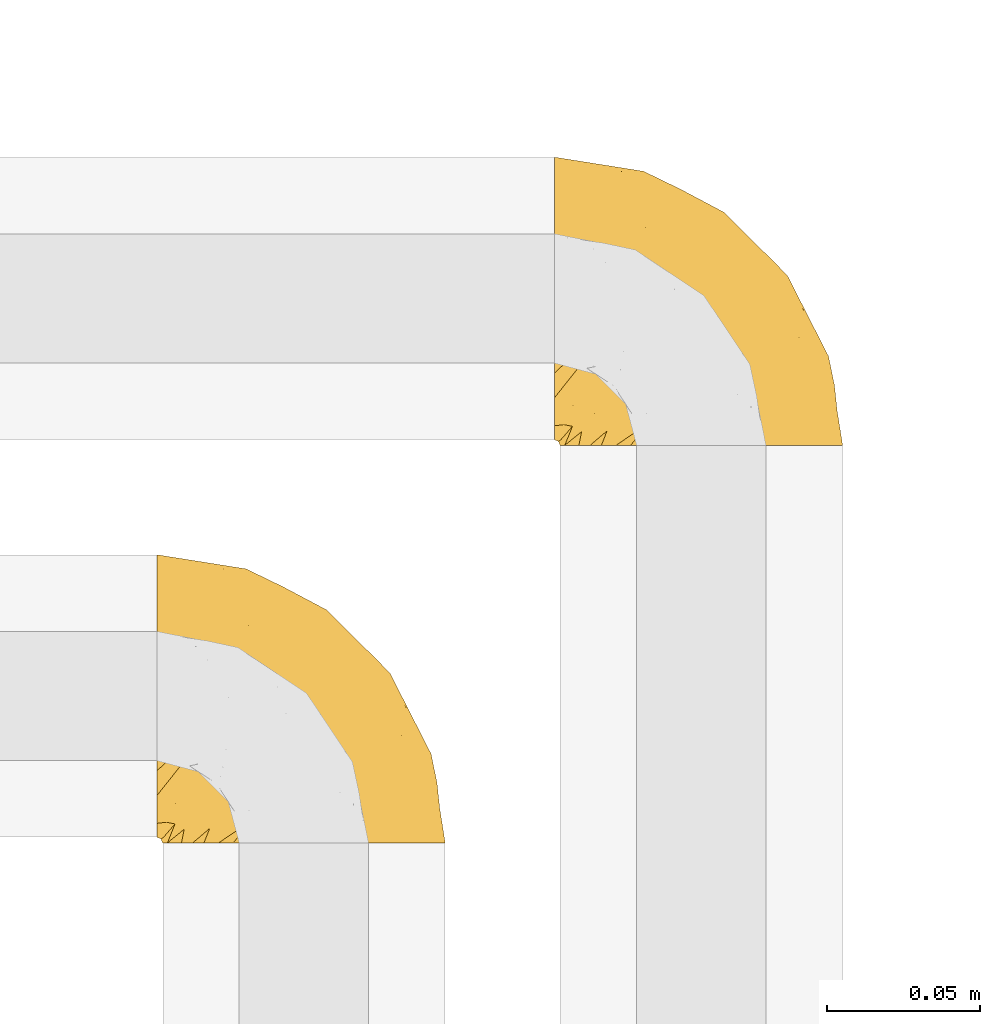
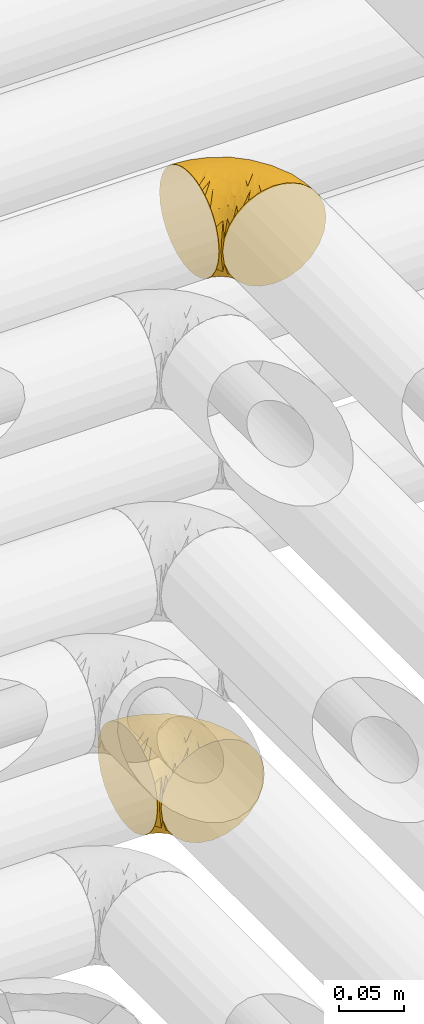
# One storey, part 277 of 827: 2 coverings.
"""IFC2X3 building model written with IfcOpenShell, lengths in millimetres."""

from ifc_helpers import new_model, entity, si_unit, converted_unit, derived_unit, direction, frame, origin, place, context, subcontext, project, spatial, faceted_brep, element, save


model = new_model("IFC2X3")

# Units and contexts
model_context = context("Model", 3, precision=0.01, world=origin(), true_north=direction((6.12303176911189e-17, 1.0)))
body_context = subcontext(model_context, "Body", "Model", "MODEL_VIEW")
ifc_project = project(units=[si_unit("LENGTHUNIT", "METRE", prefix="MILLI"), si_unit("AREAUNIT", "SQUARE_METRE"), si_unit("VOLUMEUNIT", "CUBIC_METRE"), converted_unit("PLANEANGLEUNIT", "DEGREE", entity("IfcRatioMeasure", 0.0174532925199433), si_unit("PLANEANGLEUNIT", "RADIAN"), dimensions=[0, 0, 0, 0, 0, 0, 0]), si_unit("MASSUNIT", "GRAM", prefix="KILO"), derived_unit("MASSDENSITYUNIT", [(si_unit("MASSUNIT", "GRAM", prefix="KILO"), 1), (si_unit("LENGTHUNIT", "METRE"), -3)]), derived_unit("MOMENTOFINERTIAUNIT", [(si_unit("LENGTHUNIT", "METRE"), 4)]), si_unit("TIMEUNIT", "SECOND"), si_unit("FREQUENCYUNIT", "HERTZ"), si_unit("THERMODYNAMICTEMPERATUREUNIT", "DEGREE_CELSIUS"), derived_unit("THERMALTRANSMITTANCEUNIT", [(si_unit("MASSUNIT", "GRAM", prefix="KILO"), 1), (si_unit("THERMODYNAMICTEMPERATUREUNIT", "KELVIN"), -1), (si_unit("TIMEUNIT", "SECOND"), -3)]), derived_unit("VOLUMETRICFLOWRATEUNIT", [(si_unit("LENGTHUNIT", "METRE"), 3), (si_unit("TIMEUNIT", "SECOND"), -1)]), derived_unit("MASSFLOWRATEUNIT", [(si_unit("MASSUNIT", "GRAM", prefix="KILO"), 1), (si_unit("TIMEUNIT", "SECOND"), -1)]), derived_unit("ROTATIONALFREQUENCYUNIT", [(si_unit("TIMEUNIT", "SECOND"), -1)]), si_unit("ELECTRICCURRENTUNIT", "AMPERE"), si_unit("ELECTRICVOLTAGEUNIT", "VOLT"), si_unit("POWERUNIT", "WATT"), si_unit("FORCEUNIT", "NEWTON", prefix="KILO"), si_unit("ILLUMINANCEUNIT", "LUX"), si_unit("LUMINOUSFLUXUNIT", "LUMEN"), si_unit("LUMINOUSINTENSITYUNIT", "CANDELA"), derived_unit("USERDEFINED", [(si_unit("MASSUNIT", "GRAM", prefix="KILO"), -1), (si_unit("LENGTHUNIT", "METRE"), -2), (si_unit("TIMEUNIT", "SECOND"), 3), (si_unit("LUMINOUSFLUXUNIT", "LUMEN"), 1)]), derived_unit("LINEARVELOCITYUNIT", [(si_unit("LENGTHUNIT", "METRE"), 1), (si_unit("TIMEUNIT", "SECOND"), -1)]), si_unit("PRESSUREUNIT", "PASCAL"), derived_unit("USERDEFINED", [(si_unit("LENGTHUNIT", "METRE"), -2), (si_unit("MASSUNIT", "GRAM", prefix="KILO"), 1), (si_unit("TIMEUNIT", "SECOND"), -2)]), derived_unit("LINEARFORCEUNIT", [(si_unit("MASSUNIT", "GRAM", prefix="KILO"), 1), (si_unit("LENGTHUNIT", "METRE"), 1), (si_unit("TIMEUNIT", "SECOND"), -2), (si_unit("LENGTHUNIT", "METRE"), -1)]), derived_unit("PLANARFORCEUNIT", [(si_unit("MASSUNIT", "GRAM", prefix="KILO"), 1), (si_unit("LENGTHUNIT", "METRE"), 1), (si_unit("TIMEUNIT", "SECOND"), -2), (si_unit("LENGTHUNIT", "METRE"), -2)])], contexts=[model_context])

# Site, building, storey
site_placement = place(None, origin())
site = spatial("IfcSite", under=ifc_project, at=site_placement, CompositionType="ELEMENT")
building_placement = place(site_placement, origin())
building = spatial("IfcBuilding", under=site, at=building_placement, CompositionType="ELEMENT")
storey_placement = place(building_placement, frame((0.0, 0.0, 28200.0)))
storey = spatial("IfcBuildingStorey", under=building, at=storey_placement, Name="08", CompositionType="ELEMENT", Elevation=28200.0)

# Coverings
covering_1_placement = place(storey_placement, frame((35680.44, 14440.41, 3352.2)))
element("IfcCovering", 1, at=covering_1_placement, inside=storey, Name=":ADSK_", ObjectType=":ADSK_", PredefinedType="INSULATION", context=body_context, shape_type="Brep", body=[
    faceted_brep([(1.6, 78.41, 83.91), (1.6, 85.72, 76.59), (1.6, 91.22, 67.83), (1.6, 94.64, 58.07), (1.6, 95.8, 47.8), (1.6, 94.64, 37.51), (1.6, 91.22, 27.74), (1.6, 85.71, 18.98), (1.6, 78.39, 11.67), (1.6, 69.63, 6.17), (1.6, 59.87, 2.75), (1.6, 49.6, 1.6), (1.6, 45.45, 2.06), (1.6, 42.38, 2.41), (1.6, 39.31, 2.75), (1.6, 34.43, 4.46), (1.6, 29.54, 6.17), (1.6, 25.16, 8.93), (1.6, 20.78, 11.68), (1.6, 17.13, 15.34), (1.6, 13.47, 19.0), (1.6, 7.97, 27.76), (1.6, 6.26, 32.64), (1.6, 4.55, 37.52), (1.6, 3.4, 47.8), (1.6, 4.55, 58.08), (1.6, 6.26, 62.96), (1.6, 7.97, 67.85), (1.6, 13.48, 76.61), (1.6, 17.14, 80.26), (1.6, 20.8, 83.92), (1.6, 25.18, 86.67), (1.6, 29.56, 89.42), (1.6, 34.44, 91.13), (1.6, 39.32, 92.84), (1.6, 42.39, 93.18), (1.6, 45.45, 93.53), (1.6, 49.6, 94.0), (1.6, 59.88, 92.84), (1.6, 69.65, 89.42), (3.4, 1.6, 47.8), (4.97, 1.6, 35.84), (9.58, 1.6, 24.7), (13.26, 1.6, 19.91), (16.93, 1.6, 15.13), (21.71, 1.6, 11.46), (26.5, 1.6, 7.78), (32.07, 1.6, 5.48), (37.64, 1.6, 3.17), (41.25, 1.6, 2.69), (43.34, 1.6, 2.42), (45.42, 1.6, 2.14), (49.6, 1.6, 1.6), (61.55, 1.6, 3.17), (72.7, 1.6, 7.78), (82.26, 1.6, 15.13), (89.61, 1.6, 24.7), (94.22, 1.6, 35.84), (95.8, 1.6, 47.8), (94.22, 1.6, 59.75), (89.61, 1.6, 70.9), (82.26, 1.6, 80.46), (72.7, 1.6, 87.81), (61.55, 1.6, 92.42), (49.6, 1.6, 94.0), (45.42, 1.6, 93.45), (41.25, 1.6, 92.9), (37.64, 1.6, 92.42), (32.07, 1.6, 90.11), (26.5, 1.6, 87.81), (21.71, 1.6, 84.13), (16.93, 1.6, 80.46), (13.26, 1.6, 75.68), (9.58, 1.6, 70.9), (4.97, 1.6, 59.75), (81.55, 36.81, 71.98), (90.4, 23.28, 63.6), (83.0, 45.8, 59.72), (91.18, 30.7, 47.8), (93.13, 21.2, 55.16), (94.0, 12.96, 47.8), (66.19, 66.19, 63.76), (70.92, 54.51, 72.22), (85.95, 17.98, 74.18), (49.74, 36.69, 92.52), (35.54, 35.54, 94.0), (38.14, 31.64, 94.0), (40.74, 27.75, 94.0), (43.34, 23.86, 94.0), (45.94, 19.96, 94.0), (77.59, 22.8, 82.14), (71.17, 42.67, 80.34), (65.81, 33.21, 87.52), (59.03, 59.45, 79.59), (45.85, 71.5, 78.25), (45.79, 62.66, 85.01), (41.42, 54.5, 90.25), (34.51, 47.57, 93.2), (56.04, 48.81, 87.23), (15.15, 74.98, 85.55), (56.51, 18.7, 93.0), (68.39, 15.75, 89.31), (23.33, 91.17, 61.31), (42.86, 85.28, 56.86), (39.42, 82.58, 68.34), (53.58, 75.78, 65.71), (59.17, 74.98, 56.99), (59.06, 67.27, 72.15), (22.63, 87.38, 70.34), (20.55, 82.04, 78.36), (12.96, 94.0, 47.8), (56.96, 77.8, 47.8), (67.38, 67.38, 47.8), (18.72, 56.2, 93.06), (5.33, 48.85, 94.0), (9.07, 48.11, 94.0), (11.79, 47.57, 94.0), (14.51, 47.03, 94.0), (17.24, 46.48, 94.0), (19.96, 45.94, 94.0), (21.03, 65.78, 89.88), (46.48, 17.24, 94.0), (47.03, 14.51, 94.0), (47.57, 11.79, 94.0), (48.11, 9.07, 94.0), (48.48, 7.2, 94.0), (48.85, 5.33, 94.0), (30.7, 91.18, 47.8), (23.86, 43.34, 94.0), (27.75, 40.74, 94.0), (31.64, 38.14, 94.0), (31.26, 72.73, 83.7), (77.8, 56.96, 47.8), (72.75, 62.23, 55.9), (43.83, 84.49, 47.8), (84.49, 43.83, 47.8), (14.58, 12.05, 81.75), (16.17, 18.95, 86.43), (10.82, 13.02, 79.8), (4.64, 8.34, 69.84), (7.71, 14.63, 79.5), (25.13, 11.09, 88.08), (32.66, 13.66, 91.6), (34.94, 20.08, 92.93), (36.76, 9.61, 92.43), (40.48, 9.48, 93.24), (39.25, 16.1, 93.36), (3.69, 3.42, 57.25), (13.99, 26.63, 89.41), (21.85, 33.72, 92.89), (17.93, 34.77, 92.66), (15.11, 6.75, 79.58), (21.14, 13.31, 86.51), (7.21, 19.94, 83.91), (9.47, 27.05, 88.76), (32.27, 8.67, 90.94), (25.68, 26.11, 91.94), (22.18, 29.3, 91.98), (18.79, 6.32, 82.79), (10.12, 39.92, 93.16), (10.45, 6.04, 73.94), (11.29, 34.4, 91.89), (2.87, 2.87, 47.8), (31.16, 20.92, 92.22), (12.7, 21.11, 86.29), (6.31, 27.43, 88.56), (25.62, 7.54, 87.72), (21.18, 18.45, 88.33), (28.81, 23.88, 92.18), (7.45, 7.77, 71.78), (21.17, 18.43, 7.27), (16.17, 18.93, 9.17), (25.69, 26.08, 3.66), (48.85, 5.33, 1.6), (47.03, 14.51, 1.6), (47.57, 11.79, 1.6), (48.11, 9.07, 1.6), (3.69, 3.42, 38.35), (7.44, 7.76, 23.84), (14.51, 47.03, 1.6), (11.79, 47.57, 1.6), (5.33, 48.85, 1.6), (9.07, 48.11, 1.6), (7.71, 14.62, 16.1), (9.47, 27.03, 6.84), (34.94, 20.08, 2.66), (31.16, 20.92, 3.37), (40.74, 27.75, 1.6), (38.14, 31.64, 1.6), (18.79, 6.33, 12.8), (36.76, 9.61, 3.16), (40.48, 9.48, 2.35), (4.63, 8.33, 25.77), (21.14, 13.3, 9.09), (15.11, 6.74, 16.02), (14.58, 12.04, 13.85), (43.34, 23.86, 1.6), (45.94, 19.96, 1.6), (39.25, 16.1, 2.23), (7.21, 19.93, 11.69), (12.69, 21.1, 9.31), (10.14, 39.92, 2.43), (21.81, 33.68, 2.71), (22.19, 29.28, 3.61), (14.0, 26.62, 6.18), (6.66, 27.87, 6.77), (17.92, 34.75, 2.93), (10.45, 6.04, 21.66), (31.64, 38.14, 1.6), (10.64, 12.79, 16.09), (11.31, 34.41, 3.7), (19.96, 45.94, 1.6), (23.86, 43.34, 1.6), (27.75, 40.74, 1.6), (32.66, 13.66, 3.99), (46.48, 17.24, 1.6), (32.27, 8.67, 4.65), (25.13, 11.09, 7.51), (35.54, 35.54, 1.6), (28.77, 23.83, 3.43), (23.36, 6.03, 9.46), (17.24, 46.48, 1.6), (47.58, 34.52, 2.4), (93.13, 21.2, 40.43), (77.44, 23.82, 13.57), (66.78, 41.32, 11.3), (71.68, 47.62, 18.65), (74.96, 52.66, 27.26), (81.55, 36.81, 23.61), (36.7, 49.75, 3.07), (56.9, 19.07, 2.69), (83.0, 45.8, 35.87), (90.4, 23.28, 31.99), (67.83, 21.35, 6.71), (85.95, 17.98, 21.41), (39.41, 82.57, 27.24), (23.33, 91.17, 34.26), (42.87, 85.27, 38.73), (53.92, 73.89, 26.97), (66.19, 66.19, 31.83), (64.12, 62.43, 23.4), (33.13, 63.53, 6.91), (23.1, 58.45, 3.4), (16.98, 67.16, 5.84), (55.72, 76.72, 35.73), (72.75, 62.22, 39.69), (23.77, 81.54, 17.6), (18.41, 74.8, 10.38), (43.7, 75.83, 20.6), (54.53, 41.45, 5.36), (17.73, 88.2, 24.84), (38.98, 71.6, 13.87), (50.28, 56.23, 9.06), (59.02, 59.44, 15.99)], [[[0, 1, 2, 3, 4, 5, 6, 7, 8, 9, 10, 11, 12, 13, 14, 15, 16, 17, 18, 19, 20, 21, 22, 23, 24, 25, 26, 27, 28, 29, 30, 31, 32, 33, 34, 35, 36, 37, 38, 39]], [[40, 41, 42, 43, 44, 45, 46, 47, 48, 49, 50, 51, 52, 53, 54, 55, 56, 57, 58, 59, 60, 61, 62, 63, 64, 65, 66, 67, 68, 69, 70, 71, 72, 73, 74]], [[75, 76, 77]], [[78, 79, 80]], [[77, 81, 82]], [[76, 75, 83]], [[84, 85, 86, 87, 88, 89]], [[90, 91, 92]], [[76, 60, 59]], [[93, 94, 95]], [[90, 62, 61]], [[83, 61, 60]], [[96, 97, 84]], [[98, 93, 95]], [[0, 39, 99]], [[100, 84, 89]], [[62, 101, 63]], [[2, 102, 3]], [[92, 84, 100]], [[103, 102, 104]], [[103, 105, 106]], [[93, 107, 94]], [[1, 108, 2]], [[92, 101, 90]], [[108, 1, 109]], [[102, 110, 3]], [[93, 82, 107]], [[102, 108, 104]], [[111, 106, 112]], [[109, 0, 99]], [[113, 37, 114, 115, 116, 117, 118, 119]], [[120, 38, 113]], [[100, 89, 121, 122, 123, 124, 125, 126, 64]], [[127, 102, 103]], [[97, 119, 128, 129, 130, 85]], [[99, 120, 131]], [[132, 133, 77]], [[59, 80, 79]], [[1, 0, 109]], [[98, 84, 92]], [[94, 109, 131]], [[120, 39, 38]], [[93, 91, 82]], [[104, 94, 105]], [[97, 113, 119]], [[95, 120, 96]], [[83, 90, 61]], [[91, 93, 98]], [[64, 63, 100]], [[100, 63, 101]], [[77, 76, 79]], [[133, 106, 81]], [[84, 97, 85]], [[113, 96, 120]], [[113, 97, 96]], [[37, 113, 38]], [[110, 102, 127]], [[110, 4, 3]], [[103, 111, 134, 127]], [[90, 75, 91]], [[82, 81, 107]], [[91, 75, 82]], [[77, 82, 75]], [[76, 83, 60]], [[90, 83, 75]], [[105, 107, 81]], [[94, 131, 95]], [[105, 94, 107]], [[109, 94, 104]], [[120, 95, 131]], [[98, 95, 96]], [[84, 98, 96]], [[98, 92, 91]], [[106, 105, 81]], [[103, 104, 105]], [[133, 132, 112]], [[103, 106, 111]], [[77, 78, 135, 132]], [[106, 133, 112]], [[77, 133, 81]], [[120, 99, 39]], [[109, 99, 131]], [[59, 58, 80]], [[59, 79, 76]], [[90, 101, 62]], [[100, 101, 92]], [[2, 108, 102]], [[109, 104, 108]], [[78, 77, 79]], [[136, 137, 138]], [[27, 139, 140]], [[141, 142, 143]], [[144, 145, 121]], [[146, 89, 88]], [[147, 139, 25]], [[148, 149, 150]], [[136, 151, 152]], [[147, 40, 74]], [[24, 147, 25]], [[153, 148, 154]], [[33, 116, 34]], [[73, 72, 151]], [[114, 37, 36, 35, 34, 116, 115]], [[146, 155, 144]], [[156, 85, 130]], [[157, 149, 148]], [[151, 158, 152]], [[117, 33, 159]], [[29, 153, 154]], [[160, 74, 73]], [[161, 128, 119]], [[66, 65, 64, 126, 125, 124, 123, 122, 67]], [[162, 147, 24]], [[27, 140, 28]], [[149, 129, 150]], [[139, 27, 26, 25]], [[68, 144, 69]], [[129, 128, 150]], [[163, 87, 86]], [[130, 129, 149]], [[122, 145, 67]], [[153, 164, 148]], [[161, 119, 159]], [[165, 30, 154]], [[150, 154, 148]], [[128, 161, 150]], [[30, 165, 31]], [[145, 144, 68]], [[89, 146, 144]], [[87, 163, 143]], [[166, 155, 142]], [[88, 87, 143]], [[161, 154, 150]], [[154, 30, 29]], [[29, 28, 153]], [[28, 140, 153]], [[164, 153, 140]], [[140, 137, 164]], [[157, 148, 164]], [[156, 130, 157]], [[164, 137, 157]], [[157, 137, 156]], [[167, 137, 136]], [[168, 85, 156]], [[152, 168, 167]], [[167, 168, 156]], [[163, 152, 141]], [[71, 158, 72]], [[152, 167, 136]], [[88, 142, 146]], [[144, 155, 69]], [[146, 142, 155]], [[70, 166, 71]], [[142, 141, 166]], [[70, 69, 155]], [[141, 158, 71]], [[160, 73, 151]], [[138, 137, 140]], [[160, 136, 169]], [[136, 160, 151]], [[74, 160, 169]], [[152, 158, 141]], [[151, 72, 158]], [[168, 152, 163]], [[137, 167, 156]], [[163, 86, 168]], [[85, 168, 86]], [[116, 33, 117]], [[130, 149, 157]], [[67, 145, 68]], [[121, 89, 144]], [[145, 122, 121]], [[40, 147, 162]], [[169, 147, 74]], [[159, 33, 32]], [[161, 159, 32]], [[159, 119, 118, 117]], [[139, 147, 169]], [[139, 169, 138]], [[161, 32, 31]], [[141, 143, 163]], [[88, 143, 142]], [[71, 166, 141]], [[155, 166, 70]], [[139, 138, 140]], [[169, 136, 138]], [[154, 161, 165]], [[161, 31, 165]], [[170, 171, 172]], [[173, 52, 51, 50, 49, 48, 174, 175, 176]], [[177, 178, 41]], [[179, 15, 180]], [[12, 11, 181, 182, 180, 14, 13]], [[183, 21, 20]], [[19, 18, 184]], [[185, 186, 187]], [[186, 188, 187]], [[43, 189, 44]], [[190, 191, 47]], [[23, 22, 21, 192]], [[193, 194, 195]], [[40, 162, 177]], [[196, 197, 198]], [[24, 23, 177]], [[199, 200, 183]], [[201, 15, 179]], [[47, 46, 190]], [[202, 203, 204]], [[203, 172, 171]], [[205, 206, 184]], [[207, 41, 178]], [[16, 15, 201]], [[14, 180, 15]], [[204, 203, 200]], [[208, 203, 202]], [[162, 24, 177]], [[48, 47, 191]], [[198, 197, 190]], [[199, 184, 204]], [[171, 195, 209]], [[210, 211, 212]], [[206, 212, 213]], [[205, 17, 210]], [[184, 206, 204]], [[210, 212, 206]], [[185, 196, 214]], [[190, 215, 191]], [[216, 45, 214]], [[186, 217, 193]], [[190, 216, 198]], [[199, 20, 19]], [[196, 185, 187]], [[199, 183, 20]], [[184, 199, 19]], [[199, 204, 200]], [[206, 202, 204]], [[171, 183, 200]], [[203, 208, 172]], [[172, 208, 218]], [[171, 200, 203]], [[218, 188, 219]], [[195, 170, 193]], [[217, 186, 185]], [[193, 219, 186]], [[193, 170, 219]], [[207, 194, 42]], [[217, 220, 189]], [[216, 190, 46]], [[214, 196, 198]], [[44, 220, 45]], [[214, 198, 216]], [[216, 46, 45]], [[214, 45, 220]], [[42, 194, 43]], [[189, 193, 217]], [[207, 195, 194]], [[209, 195, 178]], [[41, 207, 42]], [[195, 207, 178]], [[43, 194, 189]], [[193, 189, 194]], [[171, 170, 195]], [[170, 172, 219]], [[218, 219, 172]], [[188, 186, 219]], [[206, 213, 202]], [[208, 202, 213]], [[201, 210, 16]], [[215, 190, 197]], [[215, 174, 191]], [[174, 48, 191]], [[201, 179, 221, 211]], [[210, 201, 211]], [[23, 192, 177]], [[40, 177, 41]], [[178, 177, 192]], [[21, 183, 192]], [[209, 192, 183]], [[205, 18, 17]], [[17, 16, 210]], [[217, 185, 214]], [[189, 220, 44]], [[214, 220, 217]], [[192, 209, 178]], [[171, 209, 183]], [[206, 205, 210]], [[18, 205, 184]], [[222, 197, 196, 187, 188, 218]], [[57, 223, 80]], [[224, 225, 226]], [[226, 227, 228]], [[229, 218, 208, 213, 212, 211]], [[230, 52, 173, 176, 175, 174, 215, 197]], [[231, 232, 228]], [[231, 78, 223]], [[223, 57, 232]], [[224, 233, 225]], [[233, 54, 53]], [[234, 232, 56]], [[56, 55, 234]], [[234, 224, 228]], [[235, 236, 237]], [[224, 55, 54]], [[238, 239, 240]], [[52, 230, 53]], [[241, 242, 243]], [[239, 244, 245]], [[11, 10, 242]], [[236, 6, 5]], [[7, 246, 8]], [[8, 247, 9]], [[238, 248, 235]], [[222, 229, 249]], [[242, 211, 221, 179, 180, 182, 181, 11]], [[233, 53, 230]], [[111, 112, 244]], [[250, 6, 236]], [[247, 251, 241]], [[6, 250, 7]], [[127, 236, 110]], [[249, 229, 252]], [[247, 8, 246]], [[235, 246, 250]], [[236, 5, 110]], [[235, 244, 238]], [[237, 236, 127]], [[243, 9, 247]], [[252, 229, 241]], [[56, 232, 57]], [[222, 230, 197]], [[225, 249, 252]], [[249, 233, 230]], [[54, 233, 224]], [[231, 228, 227]], [[245, 132, 231]], [[249, 225, 233]], [[226, 225, 253]], [[235, 250, 236]], [[246, 7, 250]], [[251, 247, 246]], [[243, 247, 241]], [[248, 246, 235]], [[252, 251, 253]], [[229, 222, 218]], [[230, 222, 249]], [[5, 4, 110]], [[237, 127, 134, 111]], [[238, 244, 239]], [[224, 234, 55]], [[232, 234, 228]], [[242, 241, 229]], [[10, 9, 243]], [[211, 242, 229]], [[10, 243, 242]], [[80, 223, 78]], [[80, 58, 57]], [[231, 223, 232]], [[227, 240, 239]], [[224, 226, 228]], [[240, 226, 253]], [[227, 239, 245]], [[226, 240, 227]], [[251, 248, 253]], [[240, 253, 248]], [[244, 235, 237]], [[237, 111, 244]], [[132, 245, 112]], [[112, 245, 244]], [[135, 78, 231, 132]], [[227, 245, 231]], [[248, 238, 240]], [[246, 248, 251]], [[251, 252, 241]], [[225, 252, 253]]]),
])
covering_2_placement = place(storey_placement, frame((35550.5, 14310.41, 2952.2)))
element("IfcCovering", 2, at=covering_2_placement, inside=storey, Name=":ADSK_", ObjectType=":ADSK_", PredefinedType="INSULATION", context=body_context, shape_type="Brep", body=[
    faceted_brep([(1.6, 59.88, 92.84), (1.6, 69.65, 89.42), (1.6, 78.41, 83.91), (1.6, 85.72, 76.59), (1.6, 91.22, 67.83), (1.6, 94.64, 58.07), (1.6, 95.8, 47.8), (1.6, 94.64, 37.51), (1.6, 91.22, 27.74), (1.6, 85.71, 18.98), (1.6, 78.39, 11.67), (1.6, 69.63, 6.17), (1.6, 59.87, 2.75), (1.6, 49.6, 1.6), (1.6, 45.45, 2.06), (1.6, 42.38, 2.41), (1.6, 39.31, 2.75), (1.6, 34.43, 4.46), (1.6, 29.54, 6.17), (1.6, 25.16, 8.93), (1.6, 20.78, 11.68), (1.6, 17.13, 15.34), (1.6, 13.47, 19.0), (1.6, 7.97, 27.76), (1.6, 6.26, 32.64), (1.6, 4.55, 37.52), (1.6, 3.4, 47.8), (1.6, 4.55, 58.08), (1.6, 6.26, 62.96), (1.6, 7.97, 67.85), (1.6, 13.48, 76.61), (1.6, 17.14, 80.26), (1.6, 20.8, 83.92), (1.6, 25.18, 86.67), (1.6, 29.56, 89.42), (1.6, 34.44, 91.13), (1.6, 39.32, 92.84), (1.6, 42.39, 93.18), (1.6, 45.45, 93.53), (1.6, 49.6, 94.0), (3.4, 1.6, 47.8), (4.97, 1.6, 35.84), (9.58, 1.6, 24.7), (13.26, 1.6, 19.91), (16.93, 1.6, 15.13), (21.71, 1.6, 11.46), (26.5, 1.6, 7.78), (32.07, 1.6, 5.48), (37.64, 1.6, 3.17), (41.25, 1.6, 2.69), (43.34, 1.6, 2.42), (45.42, 1.6, 2.14), (49.6, 1.6, 1.6), (61.55, 1.6, 3.17), (72.7, 1.6, 7.78), (82.26, 1.6, 15.13), (89.61, 1.6, 24.7), (94.22, 1.6, 35.84), (95.8, 1.6, 47.8), (94.22, 1.6, 59.75), (89.61, 1.6, 70.9), (82.26, 1.6, 80.46), (72.7, 1.6, 87.81), (61.55, 1.6, 92.42), (49.6, 1.6, 94.0), (45.42, 1.6, 93.45), (41.25, 1.6, 92.9), (37.64, 1.6, 92.42), (32.07, 1.6, 90.11), (26.5, 1.6, 87.81), (21.71, 1.6, 84.13), (16.93, 1.6, 80.46), (13.26, 1.6, 75.68), (9.58, 1.6, 70.9), (4.97, 1.6, 59.75), (81.55, 36.81, 71.98), (90.4, 23.28, 63.6), (83.0, 45.8, 59.72), (91.18, 30.7, 47.8), (93.13, 21.2, 55.16), (94.0, 12.96, 47.8), (66.19, 66.19, 63.76), (70.92, 54.51, 72.22), (85.95, 17.98, 74.18), (49.74, 36.69, 92.52), (35.54, 35.54, 94.0), (38.14, 31.64, 94.0), (40.74, 27.75, 94.0), (43.34, 23.86, 94.0), (45.94, 19.96, 94.0), (77.59, 22.8, 82.14), (71.17, 42.67, 80.34), (65.81, 33.21, 87.52), (59.03, 59.45, 79.59), (45.85, 71.5, 78.25), (45.79, 62.66, 85.01), (41.42, 54.5, 90.25), (34.51, 47.57, 93.2), (56.04, 48.81, 87.23), (15.15, 74.98, 85.55), (56.51, 18.7, 93.0), (68.39, 15.75, 89.31), (23.33, 91.17, 61.31), (42.86, 85.28, 56.86), (39.42, 82.58, 68.34), (53.58, 75.78, 65.71), (59.17, 74.98, 56.99), (59.06, 67.27, 72.15), (22.63, 87.38, 70.34), (20.55, 82.04, 78.36), (12.96, 94.0, 47.8), (56.96, 77.8, 47.8), (67.38, 67.38, 47.8), (18.72, 56.2, 93.06), (5.33, 48.85, 94.0), (9.07, 48.11, 94.0), (11.79, 47.57, 94.0), (14.51, 47.03, 94.0), (17.24, 46.48, 94.0), (19.96, 45.94, 94.0), (21.03, 65.78, 89.88), (46.48, 17.24, 94.0), (47.03, 14.51, 94.0), (47.57, 11.79, 94.0), (48.11, 9.07, 94.0), (48.48, 7.2, 94.0), (48.85, 5.33, 94.0), (30.7, 91.18, 47.8), (23.86, 43.34, 94.0), (27.75, 40.74, 94.0), (31.64, 38.14, 94.0), (31.26, 72.73, 83.7), (77.8, 56.96, 47.8), (72.75, 62.23, 55.9), (43.83, 84.49, 47.8), (84.49, 43.83, 47.8), (14.58, 12.05, 81.75), (16.17, 18.95, 86.43), (10.82, 13.02, 79.8), (4.64, 8.34, 69.84), (7.71, 14.63, 79.5), (25.13, 11.09, 88.08), (32.66, 13.66, 91.6), (34.94, 20.08, 92.93), (36.76, 9.61, 92.43), (40.48, 9.48, 93.24), (39.25, 16.1, 93.36), (3.69, 3.42, 57.25), (13.99, 26.63, 89.41), (21.85, 33.72, 92.89), (17.93, 34.77, 92.66), (15.11, 6.75, 79.58), (21.14, 13.31, 86.51), (7.21, 19.94, 83.91), (9.47, 27.05, 88.76), (32.27, 8.67, 90.94), (25.68, 26.11, 91.94), (22.18, 29.3, 91.98), (18.79, 6.32, 82.79), (10.12, 39.92, 93.16), (10.45, 6.04, 73.94), (11.29, 34.4, 91.89), (2.87, 2.87, 47.8), (31.16, 20.92, 92.22), (12.7, 21.11, 86.29), (6.31, 27.43, 88.56), (25.62, 7.54, 87.72), (21.18, 18.45, 88.33), (28.81, 23.88, 92.18), (7.45, 7.77, 71.78), (21.14, 13.3, 9.09), (25.13, 11.09, 7.51), (18.79, 6.33, 12.8), (48.85, 5.33, 1.6), (47.03, 14.51, 1.6), (47.57, 11.79, 1.6), (48.11, 9.07, 1.6), (3.69, 3.42, 38.35), (7.44, 7.76, 23.84), (14.51, 47.03, 1.6), (11.79, 47.57, 1.6), (5.33, 48.85, 1.6), (9.07, 48.11, 1.6), (7.71, 14.62, 16.1), (9.47, 27.03, 6.84), (34.94, 20.08, 2.66), (31.16, 20.92, 3.37), (40.74, 27.75, 1.6), (38.14, 31.64, 1.6), (36.76, 9.61, 3.16), (40.48, 9.48, 2.35), (4.63, 8.33, 25.77), (15.11, 6.74, 16.02), (14.58, 12.04, 13.85), (43.34, 23.86, 1.6), (45.94, 19.96, 1.6), (39.25, 16.1, 2.23), (7.21, 19.93, 11.69), (12.69, 21.1, 9.31), (10.14, 39.92, 2.43), (21.81, 33.68, 2.71), (22.19, 29.28, 3.61), (14.0, 26.62, 6.18), (25.69, 26.08, 3.66), (16.17, 18.93, 9.17), (6.66, 27.87, 6.77), (17.92, 34.75, 2.93), (10.45, 6.04, 21.66), (31.64, 38.14, 1.6), (10.64, 12.79, 16.09), (11.31, 34.41, 3.7), (19.96, 45.94, 1.6), (23.86, 43.34, 1.6), (27.75, 40.74, 1.6), (32.66, 13.66, 3.99), (46.48, 17.24, 1.6), (32.27, 8.67, 4.65), (35.54, 35.54, 1.6), (28.77, 23.83, 3.43), (21.17, 18.43, 7.27), (23.36, 6.03, 9.46), (17.24, 46.48, 1.6), (47.58, 34.52, 2.4), (93.13, 21.2, 40.43), (77.44, 23.82, 13.57), (66.78, 41.32, 11.3), (71.68, 47.62, 18.65), (74.96, 52.66, 27.26), (81.55, 36.81, 23.61), (36.7, 49.75, 3.07), (56.9, 19.07, 2.69), (83.0, 45.8, 35.87), (90.4, 23.28, 31.99), (67.83, 21.35, 6.71), (85.95, 17.98, 21.41), (39.41, 82.57, 27.24), (23.33, 91.17, 34.26), (42.87, 85.27, 38.73), (53.92, 73.89, 26.97), (66.19, 66.19, 31.83), (64.12, 62.43, 23.4), (33.13, 63.53, 6.91), (23.1, 58.45, 3.4), (16.98, 67.16, 5.84), (55.72, 76.72, 35.73), (72.75, 62.22, 39.69), (23.77, 81.54, 17.6), (18.41, 74.8, 10.38), (43.7, 75.83, 20.6), (54.53, 41.45, 5.36), (17.73, 88.2, 24.84), (38.98, 71.6, 13.87), (50.28, 56.23, 9.06), (59.02, 59.44, 15.99)], [[[0, 1, 2, 3, 4, 5, 6, 7, 8, 9, 10, 11, 12, 13, 14, 15, 16, 17, 18, 19, 20, 21, 22, 23, 24, 25, 26, 27, 28, 29, 30, 31, 32, 33, 34, 35, 36, 37, 38, 39]], [[40, 41, 42, 43, 44, 45, 46, 47, 48, 49, 50, 51, 52, 53, 54, 55, 56, 57, 58, 59, 60, 61, 62, 63, 64, 65, 66, 67, 68, 69, 70, 71, 72, 73, 74]], [[75, 76, 77]], [[78, 79, 80]], [[77, 81, 82]], [[76, 75, 83]], [[84, 85, 86, 87, 88, 89]], [[90, 91, 92]], [[76, 60, 59]], [[93, 94, 95]], [[90, 62, 61]], [[83, 61, 60]], [[96, 97, 84]], [[98, 93, 95]], [[2, 1, 99]], [[100, 84, 89]], [[62, 101, 63]], [[4, 102, 5]], [[92, 84, 100]], [[103, 102, 104]], [[103, 105, 106]], [[93, 107, 94]], [[3, 108, 4]], [[92, 101, 90]], [[108, 3, 109]], [[102, 110, 5]], [[93, 82, 107]], [[102, 108, 104]], [[111, 106, 112]], [[109, 2, 99]], [[113, 39, 114, 115, 116, 117, 118, 119]], [[120, 0, 113]], [[100, 89, 121, 122, 123, 124, 125, 126, 64]], [[127, 102, 103]], [[97, 119, 128, 129, 130, 85]], [[99, 120, 131]], [[132, 133, 77]], [[59, 80, 79]], [[3, 2, 109]], [[98, 84, 92]], [[94, 109, 131]], [[120, 1, 0]], [[93, 91, 82]], [[104, 94, 105]], [[97, 113, 119]], [[95, 120, 96]], [[83, 90, 61]], [[91, 93, 98]], [[64, 63, 100]], [[100, 63, 101]], [[77, 76, 79]], [[133, 106, 81]], [[84, 97, 85]], [[113, 96, 120]], [[113, 97, 96]], [[39, 113, 0]], [[110, 102, 127]], [[110, 6, 5]], [[103, 111, 134, 127]], [[90, 75, 91]], [[82, 81, 107]], [[91, 75, 82]], [[77, 82, 75]], [[76, 83, 60]], [[90, 83, 75]], [[105, 107, 81]], [[94, 131, 95]], [[105, 94, 107]], [[109, 94, 104]], [[120, 95, 131]], [[98, 95, 96]], [[84, 98, 96]], [[98, 92, 91]], [[106, 105, 81]], [[103, 104, 105]], [[112, 106, 133]], [[103, 106, 111]], [[112, 133, 132]], [[81, 77, 133]], [[77, 78, 135, 132]], [[120, 99, 1]], [[109, 99, 131]], [[59, 58, 80]], [[59, 79, 76]], [[90, 101, 62]], [[100, 101, 92]], [[4, 108, 102]], [[109, 104, 108]], [[78, 77, 79]], [[136, 137, 138]], [[29, 139, 140]], [[141, 142, 143]], [[144, 145, 121]], [[146, 89, 88]], [[147, 139, 27]], [[148, 149, 150]], [[136, 151, 152]], [[147, 40, 74]], [[26, 147, 27]], [[153, 148, 154]], [[35, 116, 36]], [[73, 72, 151]], [[114, 39, 38, 37, 36, 116, 115]], [[146, 155, 144]], [[156, 85, 130]], [[157, 149, 148]], [[151, 158, 152]], [[117, 35, 159]], [[31, 153, 154]], [[160, 74, 73]], [[161, 128, 119]], [[66, 65, 64, 126, 125, 124, 123, 122, 67]], [[162, 147, 26]], [[29, 140, 30]], [[149, 129, 150]], [[139, 29, 28, 27]], [[68, 144, 69]], [[129, 128, 150]], [[163, 87, 86]], [[130, 129, 149]], [[122, 145, 67]], [[153, 164, 148]], [[161, 119, 159]], [[165, 32, 154]], [[150, 154, 148]], [[128, 161, 150]], [[32, 165, 33]], [[145, 144, 68]], [[89, 146, 144]], [[87, 163, 143]], [[166, 155, 142]], [[88, 87, 143]], [[161, 154, 150]], [[154, 32, 31]], [[31, 30, 153]], [[30, 140, 153]], [[164, 153, 140]], [[140, 137, 164]], [[157, 148, 164]], [[156, 130, 157]], [[164, 137, 157]], [[157, 137, 156]], [[167, 137, 136]], [[168, 85, 156]], [[152, 168, 167]], [[167, 168, 156]], [[163, 152, 141]], [[71, 158, 72]], [[152, 167, 136]], [[88, 142, 146]], [[144, 155, 69]], [[146, 142, 155]], [[70, 166, 71]], [[142, 141, 166]], [[70, 69, 155]], [[141, 158, 71]], [[160, 73, 151]], [[138, 137, 140]], [[160, 136, 169]], [[136, 160, 151]], [[74, 160, 169]], [[152, 158, 141]], [[151, 72, 158]], [[168, 152, 163]], [[137, 167, 156]], [[163, 86, 168]], [[85, 168, 86]], [[116, 35, 117]], [[130, 149, 157]], [[67, 145, 68]], [[121, 89, 144]], [[145, 122, 121]], [[40, 147, 162]], [[169, 147, 74]], [[159, 35, 34]], [[161, 159, 34]], [[159, 119, 118, 117]], [[139, 147, 169]], [[139, 169, 138]], [[161, 34, 33]], [[141, 143, 163]], [[88, 143, 142]], [[71, 166, 141]], [[155, 166, 70]], [[139, 138, 140]], [[169, 136, 138]], [[154, 161, 165]], [[161, 33, 165]], [[170, 171, 172]], [[173, 52, 51, 50, 49, 48, 174, 175, 176]], [[177, 178, 41]], [[179, 17, 180]], [[14, 13, 181, 182, 180, 16, 15]], [[183, 23, 22]], [[21, 20, 184]], [[185, 186, 187]], [[186, 188, 187]], [[43, 172, 44]], [[189, 190, 47]], [[25, 24, 23, 191]], [[170, 192, 193]], [[40, 162, 177]], [[194, 195, 196]], [[26, 25, 177]], [[197, 198, 183]], [[199, 17, 179]], [[47, 46, 189]], [[200, 201, 202]], [[201, 203, 204]], [[205, 206, 184]], [[207, 41, 178]], [[18, 17, 199]], [[16, 180, 17]], [[202, 201, 198]], [[208, 201, 200]], [[162, 26, 177]], [[48, 47, 190]], [[196, 195, 189]], [[197, 184, 202]], [[204, 193, 209]], [[210, 211, 212]], [[206, 212, 213]], [[205, 19, 210]], [[184, 206, 202]], [[210, 212, 206]], [[185, 194, 214]], [[189, 215, 190]], [[216, 45, 214]], [[186, 171, 170]], [[189, 216, 196]], [[197, 22, 21]], [[194, 185, 187]], [[197, 183, 22]], [[184, 197, 21]], [[197, 202, 198]], [[206, 200, 202]], [[204, 183, 198]], [[201, 208, 203]], [[203, 208, 217]], [[204, 198, 201]], [[217, 188, 218]], [[193, 219, 170]], [[171, 186, 185]], [[170, 218, 186]], [[170, 219, 218]], [[42, 207, 192]], [[171, 220, 172]], [[216, 189, 46]], [[214, 194, 196]], [[44, 220, 45]], [[214, 196, 216]], [[216, 46, 45]], [[214, 45, 220]], [[192, 43, 42]], [[204, 203, 219]], [[207, 193, 192]], [[209, 193, 178]], [[41, 207, 42]], [[193, 207, 178]], [[43, 192, 172]], [[170, 172, 192]], [[204, 219, 193]], [[219, 203, 218]], [[217, 218, 203]], [[188, 186, 218]], [[206, 213, 200]], [[208, 200, 213]], [[199, 210, 18]], [[215, 189, 195]], [[215, 174, 190]], [[174, 48, 190]], [[199, 179, 221, 211]], [[210, 199, 211]], [[25, 191, 177]], [[40, 177, 41]], [[183, 209, 191]], [[183, 191, 23]], [[191, 178, 177]], [[205, 20, 19]], [[19, 18, 210]], [[171, 185, 214]], [[172, 220, 44]], [[214, 220, 171]], [[191, 209, 178]], [[204, 209, 183]], [[206, 205, 210]], [[20, 205, 184]], [[222, 195, 194, 187, 188, 217]], [[57, 223, 80]], [[224, 225, 226]], [[226, 227, 228]], [[229, 217, 208, 213, 212, 211]], [[230, 52, 173, 176, 175, 174, 215, 195]], [[231, 232, 228]], [[231, 78, 223]], [[223, 57, 232]], [[224, 233, 225]], [[233, 54, 53]], [[234, 232, 56]], [[56, 55, 234]], [[234, 224, 228]], [[235, 236, 237]], [[224, 55, 54]], [[238, 239, 240]], [[52, 230, 53]], [[241, 242, 243]], [[239, 244, 245]], [[13, 12, 242]], [[236, 8, 7]], [[9, 246, 10]], [[10, 247, 11]], [[238, 248, 235]], [[222, 229, 249]], [[242, 211, 221, 179, 180, 182, 181, 13]], [[233, 53, 230]], [[111, 112, 244]], [[250, 8, 236]], [[247, 251, 241]], [[8, 250, 9]], [[127, 236, 110]], [[249, 229, 252]], [[247, 10, 246]], [[235, 246, 250]], [[236, 7, 110]], [[235, 244, 238]], [[237, 236, 127]], [[243, 11, 247]], [[252, 229, 241]], [[56, 232, 57]], [[222, 230, 195]], [[225, 249, 252]], [[249, 233, 230]], [[54, 233, 224]], [[231, 228, 227]], [[245, 132, 231]], [[249, 225, 233]], [[226, 225, 253]], [[235, 250, 236]], [[246, 9, 250]], [[251, 247, 246]], [[243, 247, 241]], [[248, 246, 235]], [[252, 251, 253]], [[229, 222, 217]], [[230, 222, 249]], [[7, 6, 110]], [[237, 127, 134, 111]], [[238, 244, 239]], [[224, 234, 55]], [[232, 234, 228]], [[242, 241, 229]], [[12, 11, 243]], [[211, 242, 229]], [[12, 243, 242]], [[80, 223, 78]], [[80, 58, 57]], [[231, 223, 232]], [[227, 240, 239]], [[224, 226, 228]], [[240, 226, 253]], [[227, 239, 245]], [[226, 240, 227]], [[251, 248, 253]], [[240, 253, 248]], [[244, 235, 237]], [[237, 111, 244]], [[132, 245, 112]], [[112, 245, 244]], [[135, 78, 231, 132]], [[227, 245, 231]], [[248, 238, 240]], [[246, 248, 251]], [[251, 252, 241]], [[225, 252, 253]]]),
])

save(model, "model.ifc")
